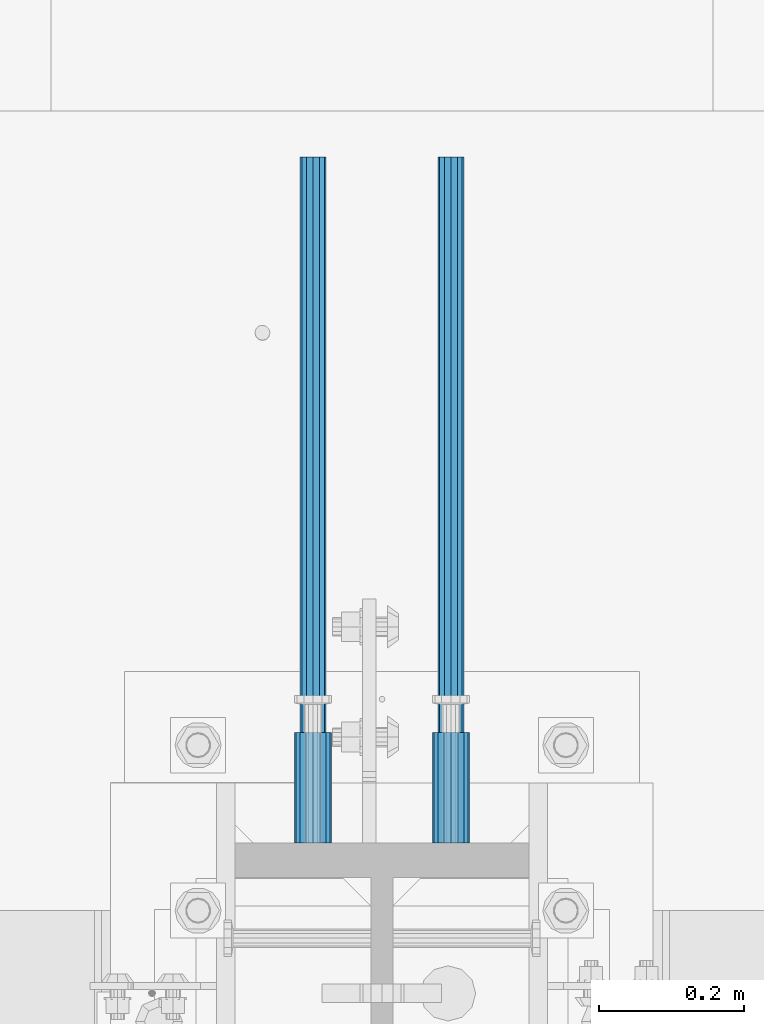
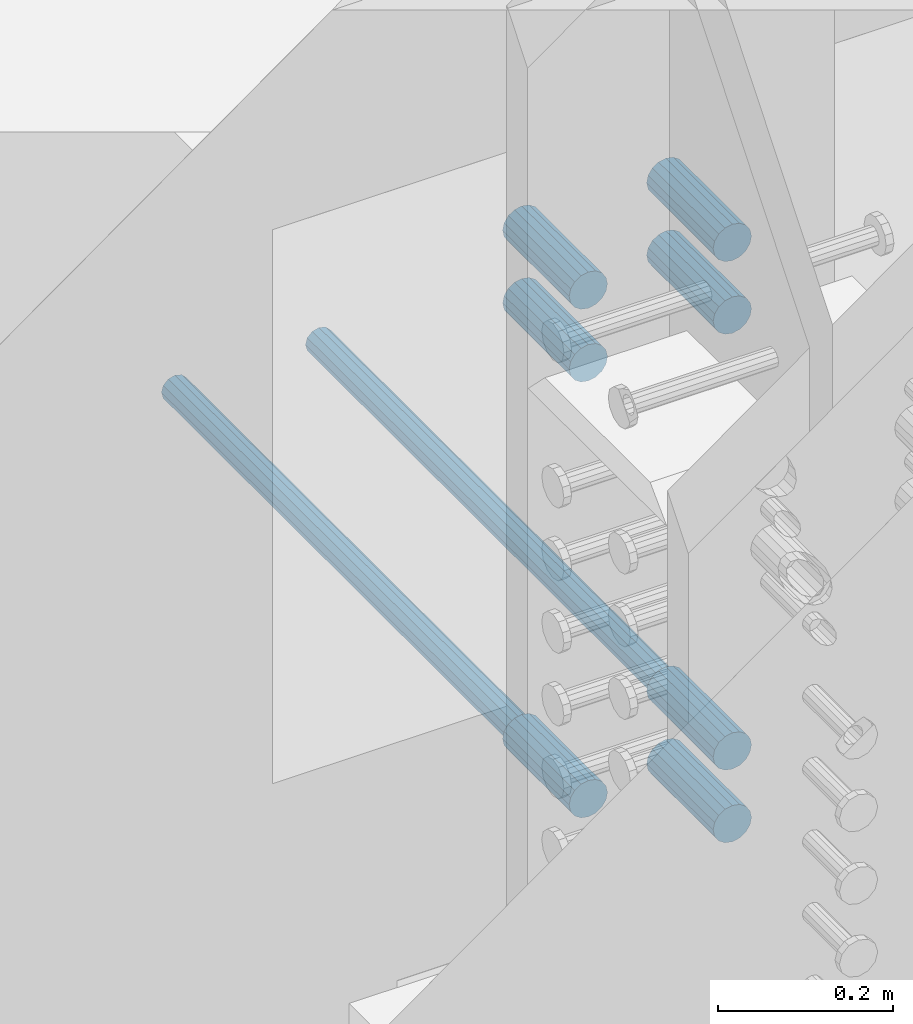
# One storey, part 1321 of 1763: 9 beams, 3 elements without a shape of their own.
"""IFC2X3 building model written with IfcOpenShell, lengths in millimetres."""

from ifc_helpers import new_model, si_unit, frame, origin_with_axes, place, context, subcontext, project, spatial, faceted_brep, material, type_object, element, aggregate, save


model = new_model("IFC2X3")

# Units and contexts
model_context = context("Model", 3, precision=1e-05, world=origin_with_axes())
body_context = subcontext(model_context, "Body", "Model", "MODEL_VIEW")
ifc_project = project(units=[si_unit("LENGTHUNIT", "METRE", prefix="MILLI"), si_unit("AREAUNIT", "SQUARE_METRE"), si_unit("VOLUMEUNIT", "CUBIC_METRE"), si_unit("MASSUNIT", "GRAM", prefix="KILO"), si_unit("TIMEUNIT", "SECOND"), si_unit("PLANEANGLEUNIT", "RADIAN"), si_unit("SOLIDANGLEUNIT", "STERADIAN"), si_unit("THERMODYNAMICTEMPERATUREUNIT", "DEGREE_CELSIUS"), si_unit("LUMINOUSINTENSITYUNIT", "LUMEN")], contexts=[model_context])

# Site, building, storey
site_placement = place(None, origin_with_axes())
site = spatial("IfcSite", under=ifc_project, at=site_placement, CompositionType="ELEMENT")
building_placement = place(site_placement, origin_with_axes())
building = spatial("IfcBuilding", under=site, at=building_placement, Name="Undefined", CompositionType="ELEMENT")
storey_placement = place(building_placement, origin_with_axes())
storey = spatial("IfcBuildingStorey", under=building, at=storey_placement, Name="Undefined", CompositionType="ELEMENT", Elevation=0.0)

# Assembly, beams
assembly_1_placement = place(storey_placement, origin_with_axes())
assembly_1 = element("IfcElementAssembly", 1, at=assembly_1_placement, inside=storey, Name="COLUMN", AssemblyPlace="NOTDEFINED", PredefinedType="RIGID_FRAME")
ifc_material = material(Name="STEEL/A706-GR.80")
beam_type_1 = type_object("IfcBeamType", PredefinedType="NOTDEFINED")
beam_1_placement = place(assembly_1_placement, frame((-23932.5872736985, 13898.5622483743, 4064.0), z_axis=(0.0, 0.0, 1.0), x_axis=(0.0, 1.0, 0.0)))
beam_1 = element("IfcBeam", 2, at=beam_1_placement, type_object=beam_type_1, material=ifc_material, Name="HALF COUPLER F", context=body_context, shape_type="Brep", body=[
    faceted_brep([(32.7659999999996, -8.95349999999962, -15.507916905568), (32.7659999999996, 0.0, -17.9070000000002), (32.7659999999996, 8.95349999999962, -15.507916905568), (32.7659999999996, 15.507916905568, -8.95350000000008), (32.7659999999996, 17.9069999999992, 0.0), (32.7659999999996, 15.507916905568, 8.95350000000008), (32.7659999999996, 8.95349999999962, 15.507916905568), (32.7659999999996, 0.0, 17.9070000000002), (32.7659999999996, -8.95349999999962, 15.507916905568), (32.7659999999996, -15.507916905568, 8.95350000000008), (32.7659999999996, -17.9069999999992, 0.0), (32.7659999999996, -15.507916905568, -8.95350000000008), (152.400103102711, -15.507916905568, 8.95350000000008), (152.400103102711, -8.95349999999962, 15.507916905568), (152.400103102711, -17.9069999999992, 0.0), (152.400103102711, -15.507916905568, -8.95350000000008), (152.400103102711, -8.95349999999962, -15.507916905568), (152.400103102711, 0.0, -17.9070000000002), (152.400103102711, 8.95349999999962, -15.507916905568), (152.400103102711, 15.507916905568, -8.95350000000008), (152.400103102711, 17.9069999999992, 0.0), (152.400103102711, 15.507916905568, 8.95350000000008), (152.400103102711, 8.95349999999962, 15.507916905568), (152.400103102711, 0.0, 17.9070000000002), (0.0, -23.466540125788, 9.72015918207308), (0.0, -17.9605122421381, 17.9605122421385), (0.0, -9.72015918207398, 23.4665401257867), (0.0, 0.0, 25.4000000000001), (0.0, 9.72015918207398, 23.4665401257867), (0.0, 17.9605122421381, 17.9605122421385), (0.0, 23.466540125788, 9.72015918207308), (0.0, 25.4000000000015, 0.0), (0.0, 23.466540125788, -9.72015918207308), (0.0, 17.9605122421381, -17.9605122421385), (0.0, 9.72015918207398, -23.4665401257867), (0.0, 0.0, -25.4000000000001), (0.0, -9.72015918207398, -23.4665401257867), (0.0, -17.9605122421381, -17.9605122421385), (0.0, -23.466540125788, -9.72015918207308), (0.0, -25.4000000000015, 0.0), (152.400103102711, -25.4000000000015, 0.0), (152.400103102711, -23.466540125788, 9.72015918207308), (152.400103102711, -17.9605122421381, 17.9605122421385), (152.400103102711, -9.72015918207398, 23.4665401257867), (152.400103102711, 0.0, 25.4000000000001), (152.400103102711, 9.72015918207398, 23.4665401257867), (152.400103102711, 17.9605122421381, 17.9605122421385), (152.400103102711, 23.466540125788, 9.72015918207308), (152.400103102711, 25.4000000000015, 0.0), (152.400103102711, 23.466540125788, -9.72015918207308), (152.400103102711, 17.9605122421381, -17.9605122421385), (152.400103102711, 9.72015918207398, -23.4665401257867), (152.400103102711, 0.0, -25.4000000000001), (152.400103102711, -9.72015918207398, -23.4665401257867), (152.400103102711, -17.9605122421381, -17.9605122421385), (152.400103102711, -23.466540125788, -9.72015918207308)], [[[0, 1, 2, 3, 4, 5, 6, 7, 8, 9, 10, 11]], [[12, 9, 8, 13]], [[14, 10, 9, 12]], [[15, 11, 10, 14]], [[16, 0, 11, 15]], [[17, 1, 0, 16]], [[18, 2, 1, 17]], [[19, 3, 2, 18]], [[20, 4, 3, 19]], [[21, 5, 4, 20]], [[22, 6, 5, 21]], [[23, 7, 6, 22]], [[13, 8, 7, 23]], [[24, 25, 26, 27, 28, 29, 30, 31, 32, 33, 34, 35, 36, 37, 38, 39]], [[24, 39, 40, 41]], [[25, 24, 41, 42]], [[26, 25, 42, 43]], [[27, 26, 43, 44]], [[28, 27, 44, 45]], [[29, 28, 45, 46]], [[30, 29, 46, 47]], [[31, 30, 47, 48]], [[32, 31, 48, 49]], [[33, 32, 49, 50]], [[34, 33, 50, 51]], [[35, 34, 51, 52]], [[36, 35, 52, 53]], [[37, 36, 53, 54]], [[38, 37, 54, 55]], [[39, 38, 55, 40]], [[54, 53, 52, 51, 50, 49, 48, 47, 46, 45, 44, 43, 42, 41, 40, 55], [21, 20, 19, 18, 17, 16, 15, 14, 12, 13, 23, 22]]]),
])
beam_2_placement = place(assembly_1_placement, frame((-24123.0872736984, 13898.5623171099, 4165.6), z_axis=(0.0, 0.0, 1.0), x_axis=(0.0, 1.0, 0.0)))
beam_2 = element("IfcBeam", 3, at=beam_2_placement, type_object=beam_type_1, material=ifc_material, Name="HALF COUPLER F", context=body_context, shape_type="Brep", body=[
    faceted_brep([(32.7659999999996, -8.95349999999962, -15.507916905568), (32.7659999999996, 0.0, -17.9070000000002), (32.7659999999996, 8.95349999999962, -15.507916905568), (32.7659999999996, 15.507916905568, -8.95350000000008), (32.7659999999996, 17.9069999999992, 0.0), (32.7659999999996, 15.507916905568, 8.95350000000008), (32.7659999999996, 8.95349999999962, 15.507916905568), (32.7659999999996, 0.0, 17.9070000000002), (32.7659999999996, -8.95349999999962, 15.507916905568), (32.7659999999996, -15.507916905568, 8.95350000000008), (32.7659999999996, -17.9069999999992, 0.0), (32.7659999999996, -15.507916905568, -8.95350000000008), (152.400103102711, -15.507916905568, 8.95350000000008), (152.400103102711, -8.95349999999962, 15.507916905568), (152.400103102711, -17.9069999999992, 0.0), (152.400103102711, -15.507916905568, -8.95350000000008), (152.400103102711, -8.95349999999962, -15.507916905568), (152.400103102711, 0.0, -17.9070000000002), (152.400103102711, 8.95349999999962, -15.507916905568), (152.400103102711, 15.507916905568, -8.95350000000008), (152.400103102711, 17.9069999999992, 0.0), (152.400103102711, 15.507916905568, 8.95350000000008), (152.400103102711, 8.95349999999962, 15.507916905568), (152.400103102711, 0.0, 17.9070000000002), (0.0, -23.466540125788, 9.72015918207308), (0.0, -17.9605122421381, 17.9605122421385), (0.0, -9.72015918207398, 23.4665401257867), (0.0, 0.0, 25.4000000000001), (0.0, 9.72015918207398, 23.4665401257867), (0.0, 17.9605122421381, 17.9605122421385), (0.0, 23.466540125788, 9.72015918207308), (0.0, 25.4000000000015, 0.0), (0.0, 23.466540125788, -9.72015918207308), (0.0, 17.9605122421381, -17.9605122421385), (0.0, 9.72015918207398, -23.4665401257867), (0.0, 0.0, -25.4000000000001), (0.0, -9.72015918207398, -23.4665401257867), (0.0, -17.9605122421381, -17.9605122421385), (0.0, -23.466540125788, -9.72015918207308), (0.0, -25.4000000000015, 0.0), (152.400103102711, -25.4000000000015, 0.0), (152.400103102711, -23.466540125788, 9.72015918207308), (152.400103102711, -17.9605122421381, 17.9605122421385), (152.400103102711, -9.72015918207398, 23.4665401257867), (152.400103102711, 0.0, 25.4000000000001), (152.400103102711, 9.72015918207398, 23.4665401257867), (152.400103102711, 17.9605122421381, 17.9605122421385), (152.400103102711, 23.466540125788, 9.72015918207308), (152.400103102711, 25.4000000000015, 0.0), (152.400103102711, 23.466540125788, -9.72015918207308), (152.400103102711, 17.9605122421381, -17.9605122421385), (152.400103102711, 9.72015918207398, -23.4665401257867), (152.400103102711, 0.0, -25.4000000000001), (152.400103102711, -9.72015918207398, -23.4665401257867), (152.400103102711, -17.9605122421381, -17.9605122421385), (152.400103102711, -23.466540125788, -9.72015918207308)], [[[0, 1, 2, 3, 4, 5, 6, 7, 8, 9, 10, 11]], [[12, 9, 8, 13]], [[14, 10, 9, 12]], [[15, 11, 10, 14]], [[16, 0, 11, 15]], [[17, 1, 0, 16]], [[18, 2, 1, 17]], [[19, 3, 2, 18]], [[20, 4, 3, 19]], [[21, 5, 4, 20]], [[22, 6, 5, 21]], [[23, 7, 6, 22]], [[13, 8, 7, 23]], [[24, 25, 26, 27, 28, 29, 30, 31, 32, 33, 34, 35, 36, 37, 38, 39]], [[24, 39, 40, 41]], [[25, 24, 41, 42]], [[26, 25, 42, 43]], [[27, 26, 43, 44]], [[28, 27, 44, 45]], [[29, 28, 45, 46]], [[30, 29, 46, 47]], [[31, 30, 47, 48]], [[32, 31, 48, 49]], [[33, 32, 49, 50]], [[34, 33, 50, 51]], [[35, 34, 51, 52]], [[36, 35, 52, 53]], [[37, 36, 53, 54]], [[38, 37, 54, 55]], [[39, 38, 55, 40]], [[54, 53, 52, 51, 50, 49, 48, 47, 46, 45, 44, 43, 42, 41, 40, 55], [21, 20, 19, 18, 17, 16, 15, 14, 12, 13, 23, 22]]]),
])
beam_3_placement = place(assembly_1_placement, frame((-23932.5872736985, 13898.5622483743, 4165.6), z_axis=(0.0, 0.0, 1.0), x_axis=(0.0, 1.0, 0.0)))
beam_3 = element("IfcBeam", 4, at=beam_3_placement, type_object=beam_type_1, material=ifc_material, Name="HALF COUPLER F", context=body_context, shape_type="Brep", body=[
    faceted_brep([(32.7659999999996, -8.95349999999962, -15.507916905568), (32.7659999999996, 0.0, -17.9070000000002), (32.7659999999996, 8.95349999999962, -15.507916905568), (32.7659999999996, 15.507916905568, -8.95350000000008), (32.7659999999996, 17.9069999999992, 0.0), (32.7659999999996, 15.507916905568, 8.95350000000008), (32.7659999999996, 8.95349999999962, 15.507916905568), (32.7659999999996, 0.0, 17.9070000000002), (32.7659999999996, -8.95349999999962, 15.507916905568), (32.7659999999996, -15.507916905568, 8.95350000000008), (32.7659999999996, -17.9069999999992, 0.0), (32.7659999999996, -15.507916905568, -8.95350000000008), (152.400103102711, -15.507916905568, 8.95350000000008), (152.400103102711, -8.95349999999962, 15.507916905568), (152.400103102711, -17.9069999999992, 0.0), (152.400103102711, -15.507916905568, -8.95350000000008), (152.400103102711, -8.95349999999962, -15.507916905568), (152.400103102711, 0.0, -17.9070000000002), (152.400103102711, 8.95349999999962, -15.507916905568), (152.400103102711, 15.507916905568, -8.95350000000008), (152.400103102711, 17.9069999999992, 0.0), (152.400103102711, 15.507916905568, 8.95350000000008), (152.400103102711, 8.95349999999962, 15.507916905568), (152.400103102711, 0.0, 17.9070000000002), (0.0, -23.466540125788, 9.72015918207308), (0.0, -17.9605122421381, 17.9605122421385), (0.0, -9.72015918207398, 23.4665401257867), (0.0, 0.0, 25.4000000000001), (0.0, 9.72015918207398, 23.4665401257867), (0.0, 17.9605122421381, 17.9605122421385), (0.0, 23.466540125788, 9.72015918207308), (0.0, 25.4000000000015, 0.0), (0.0, 23.466540125788, -9.72015918207308), (0.0, 17.9605122421381, -17.9605122421385), (0.0, 9.72015918207398, -23.4665401257867), (0.0, 0.0, -25.4000000000001), (0.0, -9.72015918207398, -23.4665401257867), (0.0, -17.9605122421381, -17.9605122421385), (0.0, -23.466540125788, -9.72015918207308), (0.0, -25.4000000000015, 0.0), (152.400103102711, -25.4000000000015, 0.0), (152.400103102711, -23.466540125788, 9.72015918207308), (152.400103102711, -17.9605122421381, 17.9605122421385), (152.400103102711, -9.72015918207398, 23.4665401257867), (152.400103102711, 0.0, 25.4000000000001), (152.400103102711, 9.72015918207398, 23.4665401257867), (152.400103102711, 17.9605122421381, 17.9605122421385), (152.400103102711, 23.466540125788, 9.72015918207308), (152.400103102711, 25.4000000000015, 0.0), (152.400103102711, 23.466540125788, -9.72015918207308), (152.400103102711, 17.9605122421381, -17.9605122421385), (152.400103102711, 9.72015918207398, -23.4665401257867), (152.400103102711, 0.0, -25.4000000000001), (152.400103102711, -9.72015918207398, -23.4665401257867), (152.400103102711, -17.9605122421381, -17.9605122421385), (152.400103102711, -23.466540125788, -9.72015918207308)], [[[0, 1, 2, 3, 4, 5, 6, 7, 8, 9, 10, 11]], [[12, 9, 8, 13]], [[14, 10, 9, 12]], [[15, 11, 10, 14]], [[16, 0, 11, 15]], [[17, 1, 0, 16]], [[18, 2, 1, 17]], [[19, 3, 2, 18]], [[20, 4, 3, 19]], [[21, 5, 4, 20]], [[22, 6, 5, 21]], [[23, 7, 6, 22]], [[13, 8, 7, 23]], [[24, 25, 26, 27, 28, 29, 30, 31, 32, 33, 34, 35, 36, 37, 38, 39]], [[24, 39, 40, 41]], [[25, 24, 41, 42]], [[26, 25, 42, 43]], [[27, 26, 43, 44]], [[28, 27, 44, 45]], [[29, 28, 45, 46]], [[30, 29, 46, 47]], [[31, 30, 47, 48]], [[32, 31, 48, 49]], [[33, 32, 49, 50]], [[34, 33, 50, 51]], [[35, 34, 51, 52]], [[36, 35, 52, 53]], [[37, 36, 53, 54]], [[38, 37, 54, 55]], [[39, 38, 55, 40]], [[54, 53, 52, 51, 50, 49, 48, 47, 46, 45, 44, 43, 42, 41, 40, 55], [21, 20, 19, 18, 17, 16, 15, 14, 12, 13, 23, 22]]]),
])
beam_4_placement = place(assembly_1_placement, frame((-24123.0872736984, 13898.5624545803, 4775.20000000009), z_axis=(0.0, 0.0, 1.0), x_axis=(0.0, 1.0, 0.0)))
beam_4 = element("IfcBeam", 5, at=beam_4_placement, type_object=beam_type_1, material=ifc_material, Name="HALF COUPLER F", context=body_context, shape_type="Brep", body=[
    faceted_brep([(32.7659999999996, -8.95349999999962, -15.507916905568), (32.7659999999996, 0.0, -17.9070000000002), (32.7659999999996, 8.95349999999962, -15.507916905568), (32.7659999999996, 15.507916905568, -8.95350000000008), (32.7659999999996, 17.9069999999992, 0.0), (32.7659999999996, 15.507916905568, 8.95350000000008), (32.7659999999996, 8.95349999999962, 15.507916905568), (32.7659999999996, 0.0, 17.9070000000002), (32.7659999999996, -8.95349999999962, 15.507916905568), (32.7659999999996, -15.507916905568, 8.95350000000008), (32.7659999999996, -17.9069999999992, 0.0), (32.7659999999996, -15.507916905568, -8.95350000000008), (152.400103102711, -15.507916905568, 8.95350000000008), (152.400103102711, -8.95349999999962, 15.507916905568), (152.400103102711, -17.9069999999992, 0.0), (152.400103102711, -15.507916905568, -8.95350000000008), (152.400103102711, -8.95349999999962, -15.507916905568), (152.400103102711, 0.0, -17.9070000000002), (152.400103102711, 8.95349999999962, -15.507916905568), (152.400103102711, 15.507916905568, -8.95350000000008), (152.400103102711, 17.9069999999992, 0.0), (152.400103102711, 15.507916905568, 8.95350000000008), (152.400103102711, 8.95349999999962, 15.507916905568), (152.400103102711, 0.0, 17.9070000000002), (0.0, -23.466540125788, 9.72015918207308), (0.0, -17.9605122421381, 17.9605122421385), (0.0, -9.72015918207398, 23.4665401257867), (0.0, 0.0, 25.4000000000001), (0.0, 9.72015918207398, 23.4665401257867), (0.0, 17.9605122421381, 17.9605122421385), (0.0, 23.466540125788, 9.72015918207308), (0.0, 25.4000000000015, 0.0), (0.0, 23.466540125788, -9.72015918207308), (0.0, 17.9605122421381, -17.9605122421385), (0.0, 9.72015918207398, -23.4665401257867), (0.0, 0.0, -25.4000000000001), (0.0, -9.72015918207398, -23.4665401257867), (0.0, -17.9605122421381, -17.9605122421385), (0.0, -23.466540125788, -9.72015918207308), (0.0, -25.4000000000015, 0.0), (152.400103102711, -25.4000000000015, 0.0), (152.400103102711, -23.466540125788, 9.72015918207308), (152.400103102711, -17.9605122421381, 17.9605122421385), (152.400103102711, -9.72015918207398, 23.4665401257867), (152.400103102711, 0.0, 25.4000000000001), (152.400103102711, 9.72015918207398, 23.4665401257867), (152.400103102711, 17.9605122421381, 17.9605122421385), (152.400103102711, 23.466540125788, 9.72015918207308), (152.400103102711, 25.4000000000015, 0.0), (152.400103102711, 23.466540125788, -9.72015918207308), (152.400103102711, 17.9605122421381, -17.9605122421385), (152.400103102711, 9.72015918207398, -23.4665401257867), (152.400103102711, 0.0, -25.4000000000001), (152.400103102711, -9.72015918207398, -23.4665401257867), (152.400103102711, -17.9605122421381, -17.9605122421385), (152.400103102711, -23.466540125788, -9.72015918207308)], [[[0, 1, 2, 3, 4, 5, 6, 7, 8, 9, 10, 11]], [[12, 9, 8, 13]], [[14, 10, 9, 12]], [[15, 11, 10, 14]], [[16, 0, 11, 15]], [[17, 1, 0, 16]], [[18, 2, 1, 17]], [[19, 3, 2, 18]], [[20, 4, 3, 19]], [[21, 5, 4, 20]], [[22, 6, 5, 21]], [[23, 7, 6, 22]], [[13, 8, 7, 23]], [[24, 25, 26, 27, 28, 29, 30, 31, 32, 33, 34, 35, 36, 37, 38, 39]], [[24, 39, 40, 41]], [[25, 24, 41, 42]], [[26, 25, 42, 43]], [[27, 26, 43, 44]], [[28, 27, 44, 45]], [[29, 28, 45, 46]], [[30, 29, 46, 47]], [[31, 30, 47, 48]], [[32, 31, 48, 49]], [[33, 32, 49, 50]], [[34, 33, 50, 51]], [[35, 34, 51, 52]], [[36, 35, 52, 53]], [[37, 36, 53, 54]], [[38, 37, 54, 55]], [[39, 38, 55, 40]], [[54, 53, 52, 51, 50, 49, 48, 47, 46, 45, 44, 43, 42, 41, 40, 55], [21, 20, 19, 18, 17, 16, 15, 14, 12, 13, 23, 22]]]),
])
beam_5_placement = place(assembly_1_placement, frame((-23932.5872736985, 13898.5623858448, 4775.20000000009), z_axis=(0.0, 0.0, 1.0), x_axis=(0.0, 1.0, 0.0)))
beam_5 = element("IfcBeam", 6, at=beam_5_placement, type_object=beam_type_1, material=ifc_material, Name="HALF COUPLER F", context=body_context, shape_type="Brep", body=[
    faceted_brep([(32.7659999999996, -8.95349999999962, -15.507916905568), (32.7659999999996, 0.0, -17.9070000000002), (32.7659999999996, 8.95349999999962, -15.507916905568), (32.7659999999996, 15.507916905568, -8.95350000000008), (32.7659999999996, 17.9069999999992, 0.0), (32.7659999999996, 15.507916905568, 8.95350000000008), (32.7659999999996, 8.95349999999962, 15.507916905568), (32.7659999999996, 0.0, 17.9070000000002), (32.7659999999996, -8.95349999999962, 15.507916905568), (32.7659999999996, -15.507916905568, 8.95350000000008), (32.7659999999996, -17.9069999999992, 0.0), (32.7659999999996, -15.507916905568, -8.95350000000008), (152.400103102711, -15.507916905568, 8.95350000000008), (152.400103102711, -8.95349999999962, 15.507916905568), (152.400103102711, -17.9069999999992, 0.0), (152.400103102711, -15.507916905568, -8.95350000000008), (152.400103102711, -8.95349999999962, -15.507916905568), (152.400103102711, 0.0, -17.9070000000002), (152.400103102711, 8.95349999999962, -15.507916905568), (152.400103102711, 15.507916905568, -8.95350000000008), (152.400103102711, 17.9069999999992, 0.0), (152.400103102711, 15.507916905568, 8.95350000000008), (152.400103102711, 8.95349999999962, 15.507916905568), (152.400103102711, 0.0, 17.9070000000002), (0.0, -23.466540125788, 9.72015918207308), (0.0, -17.9605122421381, 17.9605122421385), (0.0, -9.72015918207398, 23.4665401257867), (0.0, 0.0, 25.4000000000001), (0.0, 9.72015918207398, 23.4665401257867), (0.0, 17.9605122421381, 17.9605122421385), (0.0, 23.466540125788, 9.72015918207308), (0.0, 25.4000000000015, 0.0), (0.0, 23.466540125788, -9.72015918207308), (0.0, 17.9605122421381, -17.9605122421385), (0.0, 9.72015918207398, -23.4665401257867), (0.0, 0.0, -25.4000000000001), (0.0, -9.72015918207398, -23.4665401257867), (0.0, -17.9605122421381, -17.9605122421385), (0.0, -23.466540125788, -9.72015918207308), (0.0, -25.4000000000015, 0.0), (152.400103102711, -25.4000000000015, 0.0), (152.400103102711, -23.466540125788, 9.72015918207308), (152.400103102711, -17.9605122421381, 17.9605122421385), (152.400103102711, -9.72015918207398, 23.4665401257867), (152.400103102711, 0.0, 25.4000000000001), (152.400103102711, 9.72015918207398, 23.4665401257867), (152.400103102711, 17.9605122421381, 17.9605122421385), (152.400103102711, 23.466540125788, 9.72015918207308), (152.400103102711, 25.4000000000015, 0.0), (152.400103102711, 23.466540125788, -9.72015918207308), (152.400103102711, 17.9605122421381, -17.9605122421385), (152.400103102711, 9.72015918207398, -23.4665401257867), (152.400103102711, 0.0, -25.4000000000001), (152.400103102711, -9.72015918207398, -23.4665401257867), (152.400103102711, -17.9605122421381, -17.9605122421385), (152.400103102711, -23.466540125788, -9.72015918207308)], [[[0, 1, 2, 3, 4, 5, 6, 7, 8, 9, 10, 11]], [[12, 9, 8, 13]], [[14, 10, 9, 12]], [[15, 11, 10, 14]], [[16, 0, 11, 15]], [[17, 1, 0, 16]], [[18, 2, 1, 17]], [[19, 3, 2, 18]], [[20, 4, 3, 19]], [[21, 5, 4, 20]], [[22, 6, 5, 21]], [[23, 7, 6, 22]], [[13, 8, 7, 23]], [[24, 25, 26, 27, 28, 29, 30, 31, 32, 33, 34, 35, 36, 37, 38, 39]], [[24, 39, 40, 41]], [[25, 24, 41, 42]], [[26, 25, 42, 43]], [[27, 26, 43, 44]], [[28, 27, 44, 45]], [[29, 28, 45, 46]], [[30, 29, 46, 47]], [[31, 30, 47, 48]], [[32, 31, 48, 49]], [[33, 32, 49, 50]], [[34, 33, 50, 51]], [[35, 34, 51, 52]], [[36, 35, 52, 53]], [[37, 36, 53, 54]], [[38, 37, 54, 55]], [[39, 38, 55, 40]], [[54, 53, 52, 51, 50, 49, 48, 47, 46, 45, 44, 43, 42, 41, 40, 55], [21, 20, 19, 18, 17, 16, 15, 14, 12, 13, 23, 22]]]),
])
beam_6_placement = place(assembly_1_placement, frame((-24123.0872736984, 13898.5625920513, 4876.80000000009), z_axis=(0.0, 0.0, 1.0), x_axis=(0.0, 1.0, 0.0)))
beam_6 = element("IfcBeam", 7, at=beam_6_placement, type_object=beam_type_1, material=ifc_material, Name="HALF COUPLER F", context=body_context, shape_type="Brep", body=[
    faceted_brep([(32.7659999999996, -8.95349999999962, -15.507916905568), (32.7659999999996, 0.0, -17.9070000000002), (32.7659999999996, 8.95349999999962, -15.507916905568), (32.7659999999996, 15.507916905568, -8.95350000000008), (32.7659999999996, 17.9069999999992, 0.0), (32.7659999999996, 15.507916905568, 8.95350000000008), (32.7659999999996, 8.95349999999962, 15.507916905568), (32.7659999999996, 0.0, 17.9070000000002), (32.7659999999996, -8.95349999999962, 15.507916905568), (32.7659999999996, -15.507916905568, 8.95350000000008), (32.7659999999996, -17.9069999999992, 0.0), (32.7659999999996, -15.507916905568, -8.95350000000008), (152.400103102711, -15.507916905568, 8.95350000000008), (152.400103102711, -8.95349999999962, 15.507916905568), (152.400103102711, -17.9069999999992, 0.0), (152.400103102711, -15.507916905568, -8.95350000000008), (152.400103102711, -8.95349999999962, -15.507916905568), (152.400103102711, 0.0, -17.9070000000002), (152.400103102711, 8.95349999999962, -15.507916905568), (152.400103102711, 15.507916905568, -8.95350000000008), (152.400103102711, 17.9069999999992, 0.0), (152.400103102711, 15.507916905568, 8.95350000000008), (152.400103102711, 8.95349999999962, 15.507916905568), (152.400103102711, 0.0, 17.9070000000002), (0.0, -23.466540125788, 9.72015918207308), (0.0, -17.9605122421381, 17.9605122421385), (0.0, -9.72015918207398, 23.4665401257867), (0.0, 0.0, 25.4000000000001), (0.0, 9.72015918207398, 23.4665401257867), (0.0, 17.9605122421381, 17.9605122421385), (0.0, 23.466540125788, 9.72015918207308), (0.0, 25.4000000000015, 0.0), (0.0, 23.466540125788, -9.72015918207308), (0.0, 17.9605122421381, -17.9605122421385), (0.0, 9.72015918207398, -23.4665401257867), (0.0, 0.0, -25.4000000000001), (0.0, -9.72015918207398, -23.4665401257867), (0.0, -17.9605122421381, -17.9605122421385), (0.0, -23.466540125788, -9.72015918207308), (0.0, -25.4000000000015, 0.0), (152.400103102711, -25.4000000000015, 0.0), (152.400103102711, -23.466540125788, 9.72015918207308), (152.400103102711, -17.9605122421381, 17.9605122421385), (152.400103102711, -9.72015918207398, 23.4665401257867), (152.400103102711, 0.0, 25.4000000000001), (152.400103102711, 9.72015918207398, 23.4665401257867), (152.400103102711, 17.9605122421381, 17.9605122421385), (152.400103102711, 23.466540125788, 9.72015918207308), (152.400103102711, 25.4000000000015, 0.0), (152.400103102711, 23.466540125788, -9.72015918207308), (152.400103102711, 17.9605122421381, -17.9605122421385), (152.400103102711, 9.72015918207398, -23.4665401257867), (152.400103102711, 0.0, -25.4000000000001), (152.400103102711, -9.72015918207398, -23.4665401257867), (152.400103102711, -17.9605122421381, -17.9605122421385), (152.400103102711, -23.466540125788, -9.72015918207308)], [[[0, 1, 2, 3, 4, 5, 6, 7, 8, 9, 10, 11]], [[12, 9, 8, 13]], [[14, 10, 9, 12]], [[15, 11, 10, 14]], [[16, 0, 11, 15]], [[17, 1, 0, 16]], [[18, 2, 1, 17]], [[19, 3, 2, 18]], [[20, 4, 3, 19]], [[21, 5, 4, 20]], [[22, 6, 5, 21]], [[23, 7, 6, 22]], [[13, 8, 7, 23]], [[24, 25, 26, 27, 28, 29, 30, 31, 32, 33, 34, 35, 36, 37, 38, 39]], [[24, 39, 40, 41]], [[25, 24, 41, 42]], [[26, 25, 42, 43]], [[27, 26, 43, 44]], [[28, 27, 44, 45]], [[29, 28, 45, 46]], [[30, 29, 46, 47]], [[31, 30, 47, 48]], [[32, 31, 48, 49]], [[33, 32, 49, 50]], [[34, 33, 50, 51]], [[35, 34, 51, 52]], [[36, 35, 52, 53]], [[37, 36, 53, 54]], [[38, 37, 54, 55]], [[39, 38, 55, 40]], [[54, 53, 52, 51, 50, 49, 48, 47, 46, 45, 44, 43, 42, 41, 40, 55], [21, 20, 19, 18, 17, 16, 15, 14, 12, 13, 23, 22]]]),
])
beam_7_placement = place(assembly_1_placement, frame((-23932.5872736985, 13898.5625233158, 4876.80000000009), z_axis=(0.0, 0.0, 1.0), x_axis=(0.0, 1.0, 0.0)))
beam_7 = element("IfcBeam", 8, at=beam_7_placement, type_object=beam_type_1, material=ifc_material, Name="HALF COUPLER F", context=body_context, shape_type="Brep", body=[
    faceted_brep([(32.7659999999996, -8.95349999999962, -15.507916905568), (32.7659999999996, 0.0, -17.9070000000002), (32.7659999999996, 8.95349999999962, -15.507916905568), (32.7659999999996, 15.507916905568, -8.95350000000008), (32.7659999999996, 17.9069999999992, 0.0), (32.7659999999996, 15.507916905568, 8.95350000000008), (32.7659999999996, 8.95349999999962, 15.507916905568), (32.7659999999996, 0.0, 17.9070000000002), (32.7659999999996, -8.95349999999962, 15.507916905568), (32.7659999999996, -15.507916905568, 8.95350000000008), (32.7659999999996, -17.9069999999992, 0.0), (32.7659999999996, -15.507916905568, -8.95350000000008), (152.400103102711, -15.507916905568, 8.95350000000008), (152.400103102711, -8.95349999999962, 15.507916905568), (152.400103102711, -17.9069999999992, 0.0), (152.400103102711, -15.507916905568, -8.95350000000008), (152.400103102711, -8.95349999999962, -15.507916905568), (152.400103102711, 0.0, -17.9070000000002), (152.400103102711, 8.95349999999962, -15.507916905568), (152.400103102711, 15.507916905568, -8.95350000000008), (152.400103102711, 17.9069999999992, 0.0), (152.400103102711, 15.507916905568, 8.95350000000008), (152.400103102711, 8.95349999999962, 15.507916905568), (152.400103102711, 0.0, 17.9070000000002), (0.0, -23.466540125788, 9.72015918207308), (0.0, -17.9605122421381, 17.9605122421385), (0.0, -9.72015918207398, 23.4665401257867), (0.0, 0.0, 25.4000000000001), (0.0, 9.72015918207398, 23.4665401257867), (0.0, 17.9605122421381, 17.9605122421385), (0.0, 23.466540125788, 9.72015918207308), (0.0, 25.4000000000015, 0.0), (0.0, 23.466540125788, -9.72015918207308), (0.0, 17.9605122421381, -17.9605122421385), (0.0, 9.72015918207398, -23.4665401257867), (0.0, 0.0, -25.4000000000001), (0.0, -9.72015918207398, -23.4665401257867), (0.0, -17.9605122421381, -17.9605122421385), (0.0, -23.466540125788, -9.72015918207308), (0.0, -25.4000000000015, 0.0), (152.400103102711, -25.4000000000015, 0.0), (152.400103102711, -23.466540125788, 9.72015918207308), (152.400103102711, -17.9605122421381, 17.9605122421385), (152.400103102711, -9.72015918207398, 23.4665401257867), (152.400103102711, 0.0, 25.4000000000001), (152.400103102711, 9.72015918207398, 23.4665401257867), (152.400103102711, 17.9605122421381, 17.9605122421385), (152.400103102711, 23.466540125788, 9.72015918207308), (152.400103102711, 25.4000000000015, 0.0), (152.400103102711, 23.466540125788, -9.72015918207308), (152.400103102711, 17.9605122421381, -17.9605122421385), (152.400103102711, 9.72015918207398, -23.4665401257867), (152.400103102711, 0.0, -25.4000000000001), (152.400103102711, -9.72015918207398, -23.4665401257867), (152.400103102711, -17.9605122421381, -17.9605122421385), (152.400103102711, -23.466540125788, -9.72015918207308)], [[[0, 1, 2, 3, 4, 5, 6, 7, 8, 9, 10, 11]], [[12, 9, 8, 13]], [[14, 10, 9, 12]], [[15, 11, 10, 14]], [[16, 0, 11, 15]], [[17, 1, 0, 16]], [[18, 2, 1, 17]], [[19, 3, 2, 18]], [[20, 4, 3, 19]], [[21, 5, 4, 20]], [[22, 6, 5, 21]], [[23, 7, 6, 22]], [[13, 8, 7, 23]], [[24, 25, 26, 27, 28, 29, 30, 31, 32, 33, 34, 35, 36, 37, 38, 39]], [[24, 39, 40, 41]], [[25, 24, 41, 42]], [[26, 25, 42, 43]], [[27, 26, 43, 44]], [[28, 27, 44, 45]], [[29, 28, 45, 46]], [[30, 29, 46, 47]], [[31, 30, 47, 48]], [[32, 31, 48, 49]], [[33, 32, 49, 50]], [[34, 33, 50, 51]], [[35, 34, 51, 52]], [[36, 35, 52, 53]], [[37, 36, 53, 54]], [[38, 37, 54, 55]], [[39, 38, 55, 40]], [[54, 53, 52, 51, 50, 49, 48, 47, 46, 45, 44, 43, 42, 41, 40, 55], [21, 20, 19, 18, 17, 16, 15, 14, 12, 13, 23, 22]]]),
])
aggregate(assembly_1, [beam_1, beam_2, beam_3, beam_4, beam_5, beam_6, beam_7])

# Assembly, beam
assembly_2_placement = place(storey_placement, origin_with_axes())
assembly_2 = element("IfcElementAssembly", 9, at=assembly_2_placement, inside=storey, Name="REBAR", AssemblyPlace="NOTDEFINED", PredefinedType="RIGID_FRAME")
beam_type_2 = type_object("IfcBeamType", Name="#11 REBAR", PredefinedType="NOTDEFINED")
beam_8_placement = place(assembly_2_placement, frame((-23932.5872736985, 13931.3282483743, 4165.60000000009), z_axis=(0.0, 0.0, 1.0), x_axis=(0.0, 1.0, 0.0)))
beam_8 = element("IfcBeam", 10, at=beam_8_placement, type_object=beam_type_2, material=ifc_material, Name="REBAR", ObjectType="#11 REBAR", context=body_context, shape_type="Brep", body=[
    faceted_brep([(0.0, -17.9069999999992, 0.0), (0.0, -15.507916905568, -8.95349999999962), (914.400000001086, -15.507916905568, -8.95349999999962), (914.400000001086, -17.9069999999992, 0.0), (0.0, -8.95349999999962, -15.507916905568), (914.400000001086, -8.95349999999962, -15.507916905568), (0.0, 0.0, -17.9070000000002), (914.400000001086, 0.0, -17.9070000000002), (0.0, 8.95349999999962, -15.507916905568), (914.400000001086, 8.95349999999962, -15.507916905568), (0.0, 15.507916905568, -8.95349999999962), (914.400000001086, 15.507916905568, -8.95349999999962), (0.0, 17.9069999999992, 0.0), (914.400000001086, 17.9069999999992, 0.0), (0.0, 15.507916905568, 8.95349999999962), (914.400000001086, 15.507916905568, 8.95349999999962), (0.0, 8.95349999999962, 15.507916905568), (914.400000001086, 8.95349999999962, 15.507916905568), (0.0, 0.0, 17.9070000000002), (914.400000001086, 0.0, 17.9070000000002), (0.0, -8.95349999999962, 15.507916905568), (914.400000001086, -8.95349999999962, 15.507916905568), (0.0, -15.507916905568, 8.95349999999962), (914.400000001086, -15.507916905568, 8.95349999999962)], [[[0, 1, 2, 3]], [[1, 4, 5, 2]], [[4, 6, 7, 5]], [[6, 8, 9, 7]], [[8, 10, 11, 9]], [[10, 12, 13, 11]], [[12, 14, 15, 13]], [[14, 16, 17, 15]], [[16, 18, 19, 17]], [[18, 20, 21, 19]], [[20, 22, 23, 21]], [[22, 0, 3, 23]], [[5, 7, 9, 11, 13, 15, 17, 19, 21, 23, 3, 2]], [[22, 20, 18, 16, 14, 12, 10, 8, 6, 4, 1, 0]]]),
])
aggregate(assembly_2, [beam_8])

assembly_3_placement = place(storey_placement, origin_with_axes())
assembly_3 = element("IfcElementAssembly", 11, at=assembly_3_placement, inside=storey, Name="REBAR", AssemblyPlace="NOTDEFINED", PredefinedType="RIGID_FRAME")
beam_9_placement = place(assembly_3_placement, frame((-24123.0872736984, 13931.3283171099, 4165.60000000009), z_axis=(0.0, 0.0, 1.0), x_axis=(0.0, 1.0, 0.0)))
beam_9 = element("IfcBeam", 12, at=beam_9_placement, type_object=beam_type_2, material=ifc_material, Name="REBAR", ObjectType="#11 REBAR", context=body_context, shape_type="Brep", body=[
    faceted_brep([(0.0, -17.9069999999992, 0.0), (0.0, -15.507916905568, -8.95349999999962), (914.400000001086, -15.507916905568, -8.95349999999962), (914.400000001086, -17.9069999999992, 0.0), (0.0, -8.95349999999962, -15.507916905568), (914.400000001086, -8.95349999999962, -15.507916905568), (0.0, 0.0, -17.9070000000002), (914.400000001086, 0.0, -17.9070000000002), (0.0, 8.95349999999962, -15.507916905568), (914.400000001086, 8.95349999999962, -15.507916905568), (0.0, 15.507916905568, -8.95349999999962), (914.400000001086, 15.507916905568, -8.95349999999962), (0.0, 17.9069999999992, 0.0), (914.400000001086, 17.9069999999992, 0.0), (0.0, 15.507916905568, 8.95349999999962), (914.400000001086, 15.507916905568, 8.95349999999962), (0.0, 8.95349999999962, 15.507916905568), (914.400000001086, 8.95349999999962, 15.507916905568), (0.0, 0.0, 17.9070000000002), (914.400000001086, 0.0, 17.9070000000002), (0.0, -8.95349999999962, 15.507916905568), (914.400000001086, -8.95349999999962, 15.507916905568), (0.0, -15.507916905568, 8.95349999999962), (914.400000001086, -15.507916905568, 8.95349999999962)], [[[0, 1, 2, 3]], [[1, 4, 5, 2]], [[4, 6, 7, 5]], [[6, 8, 9, 7]], [[8, 10, 11, 9]], [[10, 12, 13, 11]], [[12, 14, 15, 13]], [[14, 16, 17, 15]], [[16, 18, 19, 17]], [[18, 20, 21, 19]], [[20, 22, 23, 21]], [[22, 0, 3, 23]], [[5, 7, 9, 11, 13, 15, 17, 19, 21, 23, 3, 2]], [[22, 20, 18, 16, 14, 12, 10, 8, 6, 4, 1, 0]]]),
])
aggregate(assembly_3, [beam_9])

save(model, "model.ifc")
